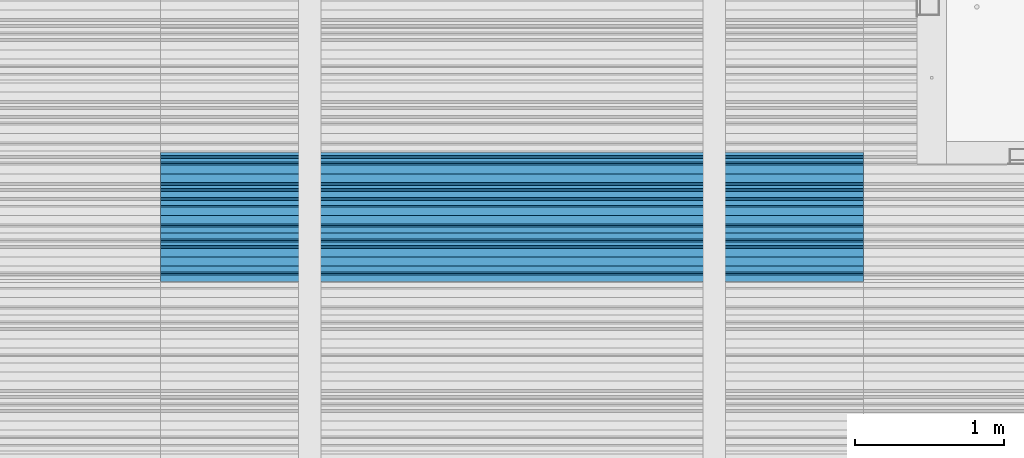
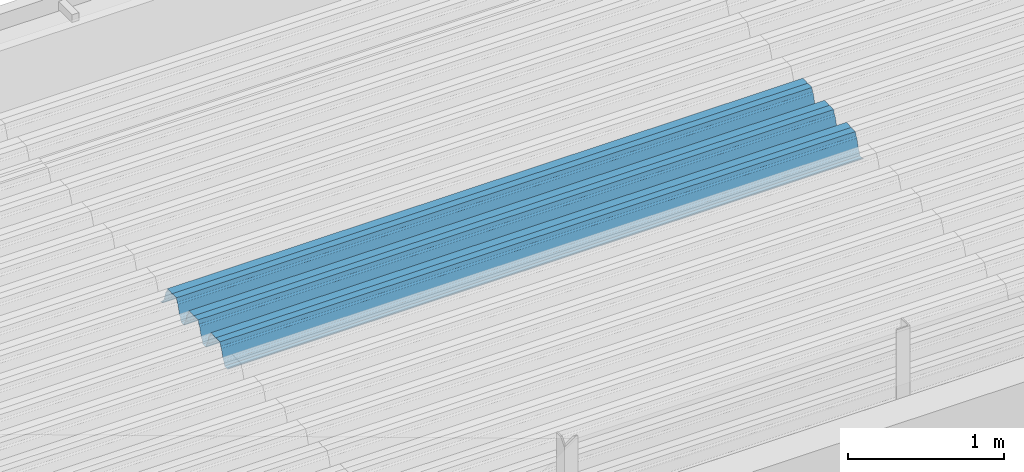
# One storey, part 31 of 153: 1 beam, 1 element without a shape of its own.
"""IFC2X3 building model written with IfcOpenShell, lengths in millimetres."""

from ifc_helpers import new_model, si_unit, frame, origin_with_axes, place, context, subcontext, project, spatial, faceted_brep, material, type_object, element, aggregate, save


model = new_model("IFC2X3")

# Units and contexts
model_context = context("Model", 3, precision=1e-05, world=origin_with_axes())
body_context = subcontext(model_context, "Body", "Model", "MODEL_VIEW")
ifc_project = project(units=[si_unit("LENGTHUNIT", "METRE", prefix="MILLI"), si_unit("AREAUNIT", "SQUARE_METRE"), si_unit("VOLUMEUNIT", "CUBIC_METRE"), si_unit("MASSUNIT", "GRAM", prefix="KILO"), si_unit("TIMEUNIT", "SECOND"), si_unit("PLANEANGLEUNIT", "RADIAN"), si_unit("SOLIDANGLEUNIT", "STERADIAN"), si_unit("THERMODYNAMICTEMPERATUREUNIT", "DEGREE_CELSIUS"), si_unit("LUMINOUSINTENSITYUNIT", "LUMEN")], contexts=[model_context])

# Site, building, storey
site_placement = place(None, origin_with_axes())
site = spatial("IfcSite", under=ifc_project, at=site_placement, CompositionType="ELEMENT")
building_placement = place(site_placement, origin_with_axes())
building = spatial("IfcBuilding", under=site, at=building_placement, CompositionType="ELEMENT")
storey_placement = place(building_placement, origin_with_axes())
storey = spatial("IfcBuildingStorey", under=building, at=storey_placement, Name="8", CompositionType="ELEMENT", Elevation=0.0)

# Assembly, beam
assembly_placement = place(storey_placement, origin_with_axes())
assembly = element("IfcElementAssembly", 1, at=assembly_placement, inside=storey, Name="Steel Assembly", AssemblyPlace="NOTDEFINED", PredefinedType="RIGID_FRAME")
ifc_material = material(Name="STEEL/S355J2")
beam_type = type_object("IfcBeamType", Name="W", PredefinedType="NOTDEFINED")
beam_placement = place(assembly_placement, frame((17251.9999999917, 17875.0145456773, 105781.023065535), z_axis=(0.0, -0.0124990270013869, 0.999921884110963), x_axis=(-1.0, 3.00000001838171e-08, 0.0)))
beam = element("IfcBeam", 2, at=beam_placement, type_object=beam_type, material=ifc_material, ObjectType="W", context=body_context, shape_type="Brep", body=[
    faceted_brep([(0.0, -412.839996337891, -77.0100021362159), (0.0, -409.160003662109, -77.0100021362014), (4717.0, -409.160003662109, -77.0100021362159), (4717.0, -412.839996337891, -77.0100021362159), (0.0, -408.070007324222, -73.4800033569045), (4717.0, -408.070007324222, -73.480003356919), (0.0, -400.339996337894, -48.0600013732619), (4717.0, -400.339996337894, -48.0600013732765), (0.0, -399.459991455082, -46.5600013732619), (4717.0, -399.459991455078, -46.5600013732765), (0.0, -390.329986572269, -36.5499992370314), (4717.0, -390.329986572266, -36.549999237046), (0.0, -389.19000244141, -34.6300010680861), (4717.0, -389.190002441403, -34.6300010681007), (0.0, -367.820007324222, 35.3400001526024), (4717.0, -367.820007324219, 35.3400001525879), (0.0, -366.989990234379, 36.8499984741502), (4717.0, -366.989990234375, 36.8499984741356), (0.0, -357.809997558597, 46.8600006103807), (4717.0, -357.809997558594, 46.8600006103661), (0.0, -356.720001220707, 48.7700004577782), (4717.0, -356.720001220703, 48.7700004577782), (0.0, -349.309997558594, 73.1500015258935), (4717.0, -349.309997558594, 73.1500015258935), (0.0, -347.850006103516, 75.2300033569481), (4717.0, -347.850006103516, 75.2300033569481), (0.0, -345.470001220707, 76.010002136245), (4717.0, -345.470001220703, 76.0100021362305), (0.0, -305.480010986332, 76.010002136245), (4717.0, -305.480010986324, 76.0100021362305), (0.0, -304.279998779301, 75.8000030517578), (4717.0, -304.279998779301, 75.8000030517724), (0.0, -291.679992675785, 71.6999969482567), (4717.0, -291.679992675785, 71.6999969482567), (0.0, -290.179992675789, 71.2300033569481), (4717.0, -290.179992675781, 71.2300033569481), (0.0, -288.720001220707, 71.6999969482567), (4717.0, -288.720001220703, 71.6999969482422), (0.0, -276.119995117191, 75.8000030517869), (4717.0, -276.119995117188, 75.8000030517724), (0.0, -274.929992675785, 76.010002136245), (4717.0, -274.929992675785, 76.010002136245), (0.0, -234.94000244141, 76.010002136245), (4717.0, -234.94000244141, 76.010002136245), (0.0, -232.550003051758, 75.2300033569627), (4717.0, -232.550003051758, 75.2300033569481), (0.0, -231.100006103519, 73.1500015258935), (4717.0, -231.100006103516, 73.1500015258789), (0.0, -223.679992675785, 48.7700004577782), (4717.0, -223.679992675781, 48.7700004577782), (0.0, -222.589996337894, 46.8600006103661), (4717.0, -222.589996337891, 46.8600006103516), (0.0, -213.410003662113, 36.8499984741502), (4717.0, -213.410003662109, 36.8499984741356), (0.0, -212.529998779301, 35.3400001526024), (4717.0, -212.529998779297, 35.3400001526024), (0.0, -191.160003662109, -34.6300010681007), (4717.0, -191.160003662109, -34.6300010681007), (0.0, -190.070007324222, -36.5499992370605), (4717.0, -190.070007324215, -36.549999237046), (0.0, -180.940002441406, -46.560001373291), (4717.0, -180.940002441406, -46.5600013732765), (0.0, -180.059997558597, -48.0600013732619), (4717.0, -180.059997558594, -48.0600013732765), (0.0, -172.330001831055, -73.480003356919), (4717.0, -172.330001831055, -73.480003356919), (0.0, -171.240005493168, -77.0100021362159), (4717.0, -171.240005493164, -77.0100021362159), (0.0, -129.330001831062, -77.0100021362014), (4717.0, -129.330001831055, -77.0100021362159), (0.0, -128.300003051761, -73.480003356919), (4717.0, -128.300003051758, -73.4800033569336), (0.0, -120.51999664307, -48.0600013732765), (4717.0, -120.519996643063, -48.0600013732765), (0.0, -119.629997253418, -46.5600013732765), (4717.0, -119.629997253418, -46.5600013732765), (0.0, -110.500000000004, -36.5499992370314), (4717.0, -110.5, -36.549999237046), (0.0, -109.419998168949, -34.6300010680861), (4717.0, -109.419998168945, -34.6300010681007), (0.0, -88.0500030517615, 35.3400001526024), (4717.0, -88.0500030517578, 35.3400001526024), (0.0, -87.160003662113, 36.8499984741356), (4717.0, -87.160003662113, 36.8499984741356), (0.0, -78.0400009155273, 46.8600006103807), (4717.0, -78.0400009155273, 46.8600006103661), (0.0, -76.8899993896557, 48.7700004577782), (4717.0, -76.8899993896521, 48.7700004577782), (0.0, -69.4800033569336, 73.1500015258935), (4717.0, -69.4800033569336, 73.1500015258935), (0.0, -68.0299987793042, 75.2300033569336), (4717.0, -68.0299987792969, 75.2300033569481), (0.0, -65.6399993896521, 76.010002136245), (4717.0, -65.6399993896484, 76.010002136245), (0.0, -25.6499996185375, 76.0100021362596), (4717.0, -25.6499996185303, 76.010002136245), (0.0, -24.5100002288891, 75.8000030517724), (4717.0, -24.5100002288818, 75.8000030517724), (0.0, -11.8500003814697, 71.6999969482567), (4717.0, -11.8500003814661, 71.6999969482567), (0.0, -10.3999996185339, 71.2300033569481), (4717.0, -10.3999996185303, 71.2300033569336), (0.0, -8.89999961853391, 71.6999969482567), (4717.0, -8.89999961853391, 71.6999969482567), (0.0, 3.71000003814333, 75.8000030517724), (4717.0, 3.71000003814697, 75.8000030517869), (0.0, 4.90000009536379, 76.0100021362596), (4717.0, 4.90000009536379, 76.010002136245), (0.0, 44.8899993896484, 76.010002136245), (4717.0, 44.8899993896484, 76.010002136245), (0.0, 47.2799987792932, 75.2300033569481), (4717.0, 47.2799987792969, 75.2300033569481), (0.0, 48.6800003051721, 73.1500015258935), (4717.0, 48.6800003051758, 73.1500015258789), (0.0, 56.1500015258753, 48.7700004577782), (4717.0, 56.1500015258789, 48.7700004577782), (0.0, 57.2400016784632, 46.8600006103807), (4717.0, 57.2400016784632, 46.8600006103661), (0.0, 66.3700027465784, 36.8499984741211), (4717.0, 66.3700027465857, 36.8499984741356), (0.0, 67.2499999999964, 35.3400001526024), (4717.0, 67.2500000000036, 35.3400001526024), (0.0, 88.6200027465748, -34.6300010681007), (4717.0, 88.620002746582, -34.6300010681152), (0.0, 89.709999084469, -36.549999237046), (4717.0, 89.7099990844727, -36.5499992370605), (0.0, 98.8899993896412, -46.5600013732765), (4717.0, 98.8899993896484, -46.5600013732765), (0.0, 99.7699966430628, -48.0600013732765), (4717.0, 99.7699966430664, -48.060001373291), (0.0, 107.499999999996, -73.4800033569336), (4717.0, 107.5, -73.480003356919), (0.0, 108.589996337887, -77.0100021362014), (4717.0, 108.589996337894, -77.0100021362159), (0.0, 112.269996643063, -77.0100021362159), (4717.0, 112.269996643066, -77.0100021362159), (0.0, 146.759994506836, -77.0100021362159), (4717.0, 146.759994506836, -77.0100021362159), (0.0, 150.440002441403, -77.0100021362159), (4717.0, 150.440002441403, -77.0100021362305), (0.0, 151.529998779297, -73.480003356919), (4717.0, 151.529998779297, -73.4800033569336), (0.0, 159.30999755859, -48.0600013732765), (4717.0, 159.309997558594, -48.0600013732765), (0.0, 160.190002441406, -46.5600013732619), (4717.0, 160.190002441406, -46.5600013732765), (0.0, 169.320007324215, -36.549999237046), (4717.0, 169.320007324222, -36.5499992370605), (0.0, 170.410003662106, -34.6300010680861), (4717.0, 170.410003662109, -34.6300010681007), (0.0, 191.779998779293, 35.3400001526024), (4717.0, 191.779998779293, 35.3400001526024), (0.0, 192.660003662109, 36.8499984741502), (4717.0, 192.660003662109, 36.8499984741356), (0.0, 201.789993286129, 46.8600006103661), (4717.0, 201.789993286133, 46.8600006103661), (0.0, 202.880004882809, 48.7700004577637), (4717.0, 202.880004882813, 48.7700004577782), (0.0, 210.350006103512, 73.150001525908), (4717.0, 210.350006103516, 73.1500015258935), (0.0, 211.800003051754, 75.2300033569481), (4717.0, 211.800003051758, 75.2300033569336), (0.0, 214.190002441406, 76.010002136245), (4717.0, 214.19000244141, 76.010002136245), (0.0, 254.179992675778, 76.010002136245), (4717.0, 254.179992675778, 76.010002136245), (0.0, 255.320007324215, 75.8000030517869), (4717.0, 255.320007324222, 75.8000030517724), (0.0, 267.980010986324, 71.6999969482713), (4717.0, 267.980010986328, 71.6999969482567), (0.0, 269.429992675778, 71.2300033569481), (4717.0, 269.429992675781, 71.2300033569481), (0.0, 270.880004882809, 71.6999969482567), (4717.0, 270.880004882813, 71.6999969482567), (0.0, 283.540008544918, 75.8000030517869), (4717.0, 283.540008544918, 75.8000030517724), (0.0, 284.679992675778, 76.010002136245), (4717.0, 284.679992675778, 76.010002136245), (0.0, 324.670013427731, 76.010002136245), (4717.0, 324.670013427738, 76.010002136245), (0.0, 327.049987792969, 75.2300033569627), (4717.0, 327.049987792969, 75.2300033569481), (0.0, 328.510009765625, 73.1500015258789), (4717.0, 328.510009765625, 73.1500015258935), (0.0, 335.980010986324, 48.7700004577782), (4717.0, 335.980010986328, 48.7700004577782), (0.0, 337.05999755859, 46.8600006103661), (4717.0, 337.059997558594, 46.8600006103516), (0.0, 346.190002441399, 36.8499984741356), (4717.0, 346.190002441406, 36.8499984741211), (0.0, 347.079986572266, 35.3400001526024), (4717.0, 347.079986572266, 35.3400001526024), (0.0, 368.450012207028, -34.6300010680861), (4717.0, 368.450012207035, -34.6300010681007), (0.0, 369.529998779293, -36.5499992370314), (4717.0, 369.529998779297, -36.549999237046), (0.0, 378.660003662106, -46.5600013732619), (4717.0, 378.660003662106, -46.5600013732765), (0.0, 379.540008544918, -48.0600013732619), (4717.0, 379.540008544922, -48.0600013732765), (0.0, 387.329986572262, -73.480003356919), (4717.0, 387.329986572266, -73.4800033569045), (0.0, 388.410003662109, -77.0100021362159), (4717.0, 388.410003662109, -77.0100021362159), (0.0, 392.100006103512, -77.0100021362159), (4717.0, 392.100006103519, -77.0100021362159), (0.0, 426.589996337887, -77.0100021362159), (4717.0, 426.589996337891, -77.0100021362159), (0.0, 430.269989013668, -77.0100021362159), (4717.0, 430.269989013672, -77.0100021362305), (0.0, 431.359985351559, -73.4800033569045), (4717.0, 431.359985351563, -73.480003356919), (0.0, 433.179992675778, -67.5699996948097), (4717.0, 433.179992675781, -67.5699996948097), (0.0, 432.220001220699, -67.2699966430373), (4717.0, 432.220001220703, -67.2699966430519), (0.0, 430.410003662106, -73.1800003051612), (4717.0, 430.410003662106, -73.1800003051758), (0.0, 429.529998779293, -76.0100021362159), (4717.0, 429.529998779293, -76.0100021362159), (0.0, 426.589996337891, -76.0100021362159), (4717.0, 426.589996337891, -76.0100021362159), (0.0, 392.100006103512, -76.0100021362159), (4717.0, 392.100006103516, -76.0100021362159), (0.0, 389.149993896481, -76.0100021362014), (4717.0, 389.149993896484, -76.0100021362159), (0.0, 388.279998779293, -73.1800003051467), (4717.0, 388.279998779301, -73.1800003051612), (0.0, 380.470001220699, -47.659999847383), (4717.0, 380.470001220703, -47.6599998473976), (0.0, 379.470001220699, -45.9599990844436), (4717.0, 379.470001220703, -45.9599990844581), (0.0, 370.350006103512, -35.9599990844581), (4717.0, 370.350006103519, -35.9599990844581), (0.0, 369.369995117184, -34.2299995422218), (4717.0, 369.369995117184, -34.2299995422218), (0.0, 347.999999999996, 35.7500000000146), (4717.0, 348.0, 35.7500000000146), (0.0, 346.999999999996, 37.4399986267235), (4717.0, 347.000000000004, 37.4399986267235), (0.0, 337.880004882809, 47.450000762954), (4717.0, 337.880004882809, 47.4500007629395), (0.0, 336.899993896481, 49.1699981689453), (4717.0, 336.899993896484, 49.1699981689599), (0.0, 329.420013427731, 73.5999984741356), (4717.0, 329.420013427734, 73.5999984741356), (0.0, 327.679992675781, 76.0699996948533), (4717.0, 327.679992675781, 76.0699996948388), (0.0, 324.829986572262, 77.010002136245), (4717.0, 324.829986572266, 77.0100021362305), (0.0, 284.589996337887, 77.010002136245), (4717.0, 284.589996337891, 77.010002136245), (0.0, 283.290008544922, 76.769996643081), (4717.0, 283.290008544922, 76.769996643081), (0.0, 270.570007324215, 72.6500015258935), (4717.0, 270.570007324219, 72.6500015258935), (0.0, 269.429992675781, 72.2799987793114), (4717.0, 269.429992675781, 72.2799987793114), (0.0, 268.279998779293, 72.650001525908), (4717.0, 268.279998779297, 72.6500015258935), (0.0, 255.570007324219, 76.769996643081), (4717.0, 255.570007324219, 76.769996643081), (0.0, 254.270004272461, 77.0100021362596), (4717.0, 254.270004272461, 77.010002136245), (0.0, 214.029998779293, 77.0100021362596), (4717.0, 214.029998779297, 77.010002136245), (0.0, 211.179992675781, 76.0699996948388), (4717.0, 211.179992675781, 76.0699996948533), (0.0, 209.440002441403, 73.5999984741356), (4717.0, 209.44000244141, 73.5999984741211), (0.0, 201.960006713864, 49.1699981689599), (4717.0, 201.960006713867, 49.1699981689453), (0.0, 200.979995727532, 47.450000762954), (4717.0, 200.979995727539, 47.4500007629395), (0.0, 191.850006103508, 37.4399986267235), (4717.0, 191.850006103516, 37.439998626709), (0.0, 190.860000610352, 35.7500000000146), (4717.0, 190.860000610352, 35.75), (0.0, 169.49000549316, -34.2299995422218), (4717.0, 169.49000549316, -34.2299995422363), (0.0, 168.509994506832, -35.9599990844581), (4717.0, 168.509994506836, -35.9599990844581), (0.0, 159.380004882805, -45.9599990844436), (4717.0, 159.380004882813, -45.9599990844581), (0.0, 158.389999389645, -47.6599998473976), (4717.0, 158.389999389645, -47.6599998474121), (0.0, 150.580001831051, -73.1800003051612), (4717.0, 150.580001831058, -73.1800003051758), (0.0, 149.710006713864, -76.0100021362159), (4717.0, 149.710006713867, -76.0100021362159), (0.0, 146.759994506836, -76.0100021362159), (4717.0, 146.759994506836, -76.0100021362159), (0.0, 112.269996643063, -76.0100021362159), (4717.0, 112.269996643063, -76.0100021362159), (0.0, 109.319999694821, -76.0100021362159), (4717.0, 109.319999694821, -76.0100021362159), (0.0, 108.449996948239, -73.1900024413917), (4717.0, 108.449996948242, -73.1900024414063), (0.0, 100.690002441406, -47.659999847383), (4717.0, 100.69000244141, -47.6599998473976), (0.0, 99.6999969482386, -45.9599990844581), (4717.0, 99.6999969482422, -45.9599990844581), (0.0, 90.5199966430664, -35.9599990844581), (4717.0, 90.5199966430664, -35.9599990844727), (0.0, 89.5400009155273, -34.2299995422218), (4717.0, 89.5400009155273, -34.2299995422218), (0.0, 68.1699981689417, 35.7500000000146), (4717.0, 68.1699981689453, 35.7500000000146), (0.0, 67.1699981689417, 37.4399986267235), (4717.0, 67.1699981689453, 37.4399986267235), (0.0, 58.0499992370569, 47.4500007629686), (4717.0, 58.0499992370605, 47.450000762954), (0.0, 57.0699996948206, 49.1699981689599), (4717.0, 57.0699996948279, 49.1699981689453), (0.0, 49.5900001525843, 73.5899963379052), (4717.0, 49.5900001525879, 73.5899963378906), (0.0, 47.9099998474085, 76.0699996948388), (4717.0, 47.9099998474121, 76.0699996948242), (0.0, 45.0499992370569, 77.010002136245), (4717.0, 45.0499992370605, 77.010002136245), (0.0, 4.82000017165774, 77.010002136245), (4717.0, 4.82000017166138, 77.010002136245), (0.0, 3.47000002860659, 76.7699966430955), (4717.0, 3.47000002860659, 76.769996643081), (0.0, -9.19999980926514, 72.6500015258935), (4717.0, -9.19999980926514, 72.6500015258789), (0.0, -10.3900003433264, 72.2799987792969), (4717.0, -10.3900003433228, 72.2799987793114), (0.0, -11.5399999618567, 72.6500015258935), (4717.0, -11.5399999618494, 72.6500015258935), (0.0, -24.2600002288855, 76.769996643081), (4717.0, -24.2600002288818, 76.769996643081), (0.0, -25.559999465946, 77.0100021362596), (4717.0, -25.5599994659424, 77.010002136245), (0.0, -65.8000030517615, 77.0100021362596), (4717.0, -65.8000030517578, 77.010002136245), (0.0, -68.6500015258862, 76.0699996948533), (4717.0, -68.6500015258825, 76.0699996948388), (0.0, -70.3899993896521, 73.5999984741356), (4717.0, -70.3899993896484, 73.5999984741211), (0.0, -77.8199996948242, 49.1800003051903), (4717.0, -77.8199996948242, 49.1800003051903), (0.0, -78.8399963378943, 47.450000762954), (4717.0, -78.8399963378906, 47.4500007629395), (0.0, -87.9700012207031, 37.4399986267235), (4717.0, -87.9700012207031, 37.4399986267235), (0.0, -88.9700012207068, 35.7500000000146), (4717.0, -88.9700012207031, 35.75), (0.0, -110.339996337894, -34.2299995422218), (4717.0, -110.339996337887, -34.2299995422218), (0.0, -111.319999694828, -35.9599990844581), (4717.0, -111.319999694824, -35.9599990844581), (0.0, -120.440002441406, -45.9599990844436), (4717.0, -120.440002441406, -45.9599990844581), (0.0, -121.44000244141, -47.6599998473976), (4717.0, -121.440002441403, -47.6599998473976), (0.0, -129.250000000004, -73.1900024413771), (4717.0, -129.25, -73.1900024413917), (0.0, -130.080001831062, -76.0100021362159), (4717.0, -130.080001831055, -76.0100021362159), (0.0, -170.5, -76.0100021362014), (4717.0, -170.5, -76.0100021362159), (0.0, -171.380004882816, -73.1900024413917), (4717.0, -171.380004882813, -73.1900024414063), (0.0, -179.139999389652, -47.6599998473976), (4717.0, -179.139999389648, -47.6599998473976), (0.0, -180.130004882816, -45.9599990844581), (4717.0, -180.130004882813, -45.9599990844581), (0.0, -189.259994506836, -35.9599990844581), (4717.0, -189.259994506832, -35.9599990844581), (0.0, -190.240005493168, -34.2299995422218), (4717.0, -190.240005493164, -34.2299995422218), (0.0, -211.610000610355, 35.7500000000146), (4717.0, -211.610000610352, 35.7500000000146), (0.0, -212.600006103519, 37.4399986267381), (4717.0, -212.600006103519, 37.4399986267235), (0.0, -221.779998779301, 47.450000762954), (4717.0, -221.779998779293, 47.4500007629395), (0.0, -222.75999450684, 49.1699981689599), (4717.0, -222.759994506836, 49.1699981689599), (0.0, -230.190002441406, 73.5999984741356), (4717.0, -230.190002441406, 73.5999984741211), (0.0, -231.919998168945, 76.0699996948388), (4717.0, -231.919998168945, 76.0699996948388), (0.0, -234.779998779301, 77.010002136245), (4717.0, -234.779998779293, 77.010002136245), (0.0, -275.010009765629, 77.010002136245), (4717.0, -275.010009765625, 77.0100021362305), (0.0, -276.359985351563, 76.769996643081), (4717.0, -276.359985351563, 76.7699966430664), (0.0, -289.029998779297, 72.6500015258789), (4717.0, -289.029998779297, 72.6500015258935), (0.0, -290.179992675785, 72.2799987793114), (4717.0, -290.179992675785, 72.2799987793114), (0.0, -291.380004882816, 72.650001525908), (4717.0, -291.380004882813, 72.6500015258935), (0.0, -304.040008544926, 76.769996643081), (4717.0, -304.040008544918, 76.769996643081), (0.0, -305.390014648441, 77.010002136245), (4717.0, -305.390014648438, 77.010002136245), (0.0, -345.63000488282, 77.0100021362596), (4717.0, -345.630004882813, 77.010002136245), (0.0, -348.480010986332, 76.0699996948388), (4717.0, -348.480010986324, 76.0699996948388), (0.0, -350.220001220707, 73.5999984741356), (4717.0, -350.220001220703, 73.5999984741211), (0.0, -357.649993896492, 49.1699981689599), (4717.0, -357.649993896484, 49.1699981689744), (0.0, -358.63000488282, 47.450000762954), (4717.0, -358.630004882813, 47.450000762954), (0.0, -367.809997558594, 37.4300003051903), (4717.0, -367.809997558594, 37.4300003051903), (0.0, -368.750000000004, 35.7299995422654), (4717.0, -368.75, 35.7299995422509), (0.0, -390.109985351566, -34.2200012207031), (4717.0, -390.109985351563, -34.2200012206886), (0.0, -391.140014648441, -35.9500007629249), (4717.0, -391.140014648438, -35.9500007629103), (0.0, -400.269989013676, -45.9599990844436), (4717.0, -400.269989013672, -45.9599990844581), (0.0, -401.269989013672, -47.6599998473976), (4717.0, -401.269989013672, -47.6599998473976), (0.0, -409.029998779297, -73.1900024413917), (4717.0, -409.029998779297, -73.1900024413917), (0.0, -409.899993896488, -76.0100021362159), (4717.0, -409.899993896481, -76.0100021362305), (0.0, -412.839996337891, -76.0100021362159), (4717.0, -412.839996337891, -76.0100021362305), (0.0, -433.179992675785, -76.0100021362159), (4717.0, -433.179992675781, -76.0100021362159), (0.0, -433.179992675785, -77.0100021362159), (4717.0, -433.179992675785, -77.0100021362305)], [[[0, 1, 2, 3]], [[1, 4, 5, 2]], [[4, 6, 7, 5]], [[6, 8, 9, 7]], [[8, 10, 11, 9]], [[10, 12, 13, 11]], [[12, 14, 15, 13]], [[14, 16, 17, 15]], [[16, 18, 19, 17]], [[18, 20, 21, 19]], [[20, 22, 23, 21]], [[22, 24, 25, 23]], [[24, 26, 27, 25]], [[26, 28, 29, 27]], [[28, 30, 31, 29]], [[30, 32, 33, 31]], [[32, 34, 35, 33]], [[34, 36, 37, 35]], [[36, 38, 39, 37]], [[38, 40, 41, 39]], [[40, 42, 43, 41]], [[42, 44, 45, 43]], [[44, 46, 47, 45]], [[46, 48, 49, 47]], [[48, 50, 51, 49]], [[50, 52, 53, 51]], [[52, 54, 55, 53]], [[54, 56, 57, 55]], [[56, 58, 59, 57]], [[58, 60, 61, 59]], [[60, 62, 63, 61]], [[62, 64, 65, 63]], [[64, 66, 67, 65]], [[66, 68, 69, 67]], [[68, 70, 71, 69]], [[70, 72, 73, 71]], [[72, 74, 75, 73]], [[74, 76, 77, 75]], [[76, 78, 79, 77]], [[78, 80, 81, 79]], [[80, 82, 83, 81]], [[82, 84, 85, 83]], [[84, 86, 87, 85]], [[86, 88, 89, 87]], [[88, 90, 91, 89]], [[90, 92, 93, 91]], [[92, 94, 95, 93]], [[94, 96, 97, 95]], [[96, 98, 99, 97]], [[98, 100, 101, 99]], [[100, 102, 103, 101]], [[102, 104, 105, 103]], [[104, 106, 107, 105]], [[106, 108, 109, 107]], [[108, 110, 111, 109]], [[110, 112, 113, 111]], [[112, 114, 115, 113]], [[114, 116, 117, 115]], [[116, 118, 119, 117]], [[118, 120, 121, 119]], [[120, 122, 123, 121]], [[122, 124, 125, 123]], [[124, 126, 127, 125]], [[126, 128, 129, 127]], [[128, 130, 131, 129]], [[130, 132, 133, 131]], [[132, 134, 135, 133]], [[134, 136, 137, 135]], [[136, 138, 139, 137]], [[138, 140, 141, 139]], [[140, 142, 143, 141]], [[142, 144, 145, 143]], [[144, 146, 147, 145]], [[146, 148, 149, 147]], [[148, 150, 151, 149]], [[150, 152, 153, 151]], [[152, 154, 155, 153]], [[154, 156, 157, 155]], [[156, 158, 159, 157]], [[158, 160, 161, 159]], [[160, 162, 163, 161]], [[162, 164, 165, 163]], [[164, 166, 167, 165]], [[166, 168, 169, 167]], [[168, 170, 171, 169]], [[170, 172, 173, 171]], [[172, 174, 175, 173]], [[174, 176, 177, 175]], [[176, 178, 179, 177]], [[178, 180, 181, 179]], [[180, 182, 183, 181]], [[182, 184, 185, 183]], [[184, 186, 187, 185]], [[186, 188, 189, 187]], [[188, 190, 191, 189]], [[190, 192, 193, 191]], [[192, 194, 195, 193]], [[194, 196, 197, 195]], [[196, 198, 199, 197]], [[198, 200, 201, 199]], [[200, 202, 203, 201]], [[202, 204, 205, 203]], [[204, 206, 207, 205]], [[206, 208, 209, 207]], [[208, 210, 211, 209]], [[210, 212, 213, 211]], [[212, 214, 215, 213]], [[214, 216, 217, 215]], [[216, 218, 219, 217]], [[218, 220, 221, 219]], [[220, 222, 223, 221]], [[222, 224, 225, 223]], [[224, 226, 227, 225]], [[226, 228, 229, 227]], [[228, 230, 231, 229]], [[230, 232, 233, 231]], [[232, 234, 235, 233]], [[234, 236, 237, 235]], [[236, 238, 239, 237]], [[238, 240, 241, 239]], [[240, 242, 243, 241]], [[242, 244, 245, 243]], [[244, 246, 247, 245]], [[246, 248, 249, 247]], [[248, 250, 251, 249]], [[250, 252, 253, 251]], [[252, 254, 255, 253]], [[254, 256, 257, 255]], [[256, 258, 259, 257]], [[258, 260, 261, 259]], [[260, 262, 263, 261]], [[262, 264, 265, 263]], [[264, 266, 267, 265]], [[266, 268, 269, 267]], [[268, 270, 271, 269]], [[270, 272, 273, 271]], [[272, 274, 275, 273]], [[274, 276, 277, 275]], [[276, 278, 279, 277]], [[278, 280, 281, 279]], [[280, 282, 283, 281]], [[282, 284, 285, 283]], [[284, 286, 287, 285]], [[286, 288, 289, 287]], [[288, 290, 291, 289]], [[290, 292, 293, 291]], [[292, 294, 295, 293]], [[294, 296, 297, 295]], [[296, 298, 299, 297]], [[298, 300, 301, 299]], [[300, 302, 303, 301]], [[302, 304, 305, 303]], [[304, 306, 307, 305]], [[306, 308, 309, 307]], [[308, 310, 311, 309]], [[310, 312, 313, 311]], [[312, 314, 315, 313]], [[314, 316, 317, 315]], [[316, 318, 319, 317]], [[318, 320, 321, 319]], [[320, 322, 323, 321]], [[322, 324, 325, 323]], [[324, 326, 327, 325]], [[326, 328, 329, 327]], [[328, 330, 331, 329]], [[330, 332, 333, 331]], [[332, 334, 335, 333]], [[334, 336, 337, 335]], [[336, 338, 339, 337]], [[338, 340, 341, 339]], [[340, 342, 343, 341]], [[342, 344, 345, 343]], [[344, 346, 347, 345]], [[346, 348, 349, 347]], [[348, 350, 351, 349]], [[350, 352, 353, 351]], [[352, 354, 355, 353]], [[354, 356, 357, 355]], [[356, 358, 359, 357]], [[358, 360, 361, 359]], [[360, 362, 363, 361]], [[362, 364, 365, 363]], [[364, 366, 367, 365]], [[366, 368, 369, 367]], [[368, 370, 371, 369]], [[370, 372, 373, 371]], [[372, 374, 375, 373]], [[374, 376, 377, 375]], [[376, 378, 379, 377]], [[378, 380, 381, 379]], [[380, 382, 383, 381]], [[382, 384, 385, 383]], [[384, 386, 387, 385]], [[386, 388, 389, 387]], [[388, 390, 391, 389]], [[390, 392, 393, 391]], [[392, 394, 395, 393]], [[394, 396, 397, 395]], [[396, 398, 399, 397]], [[398, 400, 401, 399]], [[400, 402, 403, 401]], [[402, 404, 405, 403]], [[404, 406, 407, 405]], [[406, 408, 409, 407]], [[408, 410, 411, 409]], [[410, 412, 413, 411]], [[412, 414, 415, 413]], [[414, 416, 417, 415]], [[416, 418, 419, 417]], [[418, 420, 421, 419]], [[420, 422, 423, 421]], [[422, 424, 425, 423]], [[424, 426, 427, 425]], [[426, 428, 429, 427]], [[428, 430, 431, 429]], [[430, 0, 3, 431]], [[5, 7, 9, 11, 13, 15, 17, 19, 21, 23, 25, 27, 29, 31, 33, 35, 37, 39, 41, 43, 45, 47, 49, 51, 53, 55, 57, 59, 61, 63, 65, 67, 69, 71, 73, 75, 77, 79, 81, 83, 85, 87, 89, 91, 93, 95, 97, 99, 101, 103, 105, 107, 109, 111, 113, 115, 117, 119, 121, 123, 125, 127, 129, 131, 133, 135, 137, 139, 141, 143, 145, 147, 149, 151, 153, 155, 157, 159, 161, 163, 165, 167, 169, 171, 173, 175, 177, 179, 181, 183, 185, 187, 189, 191, 193, 195, 197, 199, 201, 203, 205, 207, 209, 211, 213, 215, 217, 219, 221, 223, 225, 227, 229, 231, 233, 235, 237, 239, 241, 243, 245, 247, 249, 251, 253, 255, 257, 259, 261, 263, 265, 267, 269, 271, 273, 275, 277, 279, 281, 283, 285, 287, 289, 291, 293, 295, 297, 299, 301, 303, 305, 307, 309, 311, 313, 315, 317, 319, 321, 323, 325, 327, 329, 331, 333, 335, 337, 339, 341, 343, 345, 347, 349, 351, 353, 355, 357, 359, 361, 363, 365, 367, 369, 371, 373, 375, 377, 379, 381, 383, 385, 387, 389, 391, 393, 395, 397, 399, 401, 403, 405, 407, 409, 411, 413, 415, 417, 419, 421, 423, 425, 427, 429, 431, 3, 2]], [[430, 428, 426, 424, 422, 420, 418, 416, 414, 412, 410, 408, 406, 404, 402, 400, 398, 396, 394, 392, 390, 388, 386, 384, 382, 380, 378, 376, 374, 372, 370, 368, 366, 364, 362, 360, 358, 356, 354, 352, 350, 348, 346, 344, 342, 340, 338, 336, 334, 332, 330, 328, 326, 324, 322, 320, 318, 316, 314, 312, 310, 308, 306, 304, 302, 300, 298, 296, 294, 292, 290, 288, 286, 284, 282, 280, 278, 276, 274, 272, 270, 268, 266, 264, 262, 260, 258, 256, 254, 252, 250, 248, 246, 244, 242, 240, 238, 236, 234, 232, 230, 228, 226, 224, 222, 220, 218, 216, 214, 212, 210, 208, 206, 204, 202, 200, 198, 196, 194, 192, 190, 188, 186, 184, 182, 180, 178, 176, 174, 172, 170, 168, 166, 164, 162, 160, 158, 156, 154, 152, 150, 148, 146, 144, 142, 140, 138, 136, 134, 132, 130, 128, 126, 124, 122, 120, 118, 116, 114, 112, 110, 108, 106, 104, 102, 100, 98, 96, 94, 92, 90, 88, 86, 84, 82, 80, 78, 76, 74, 72, 70, 68, 66, 64, 62, 60, 58, 56, 54, 52, 50, 48, 46, 44, 42, 40, 38, 36, 34, 32, 30, 28, 26, 24, 22, 20, 18, 16, 14, 12, 10, 8, 6, 4, 1, 0]]]),
])
aggregate(assembly, [beam])

save(model, "model.ifc")
